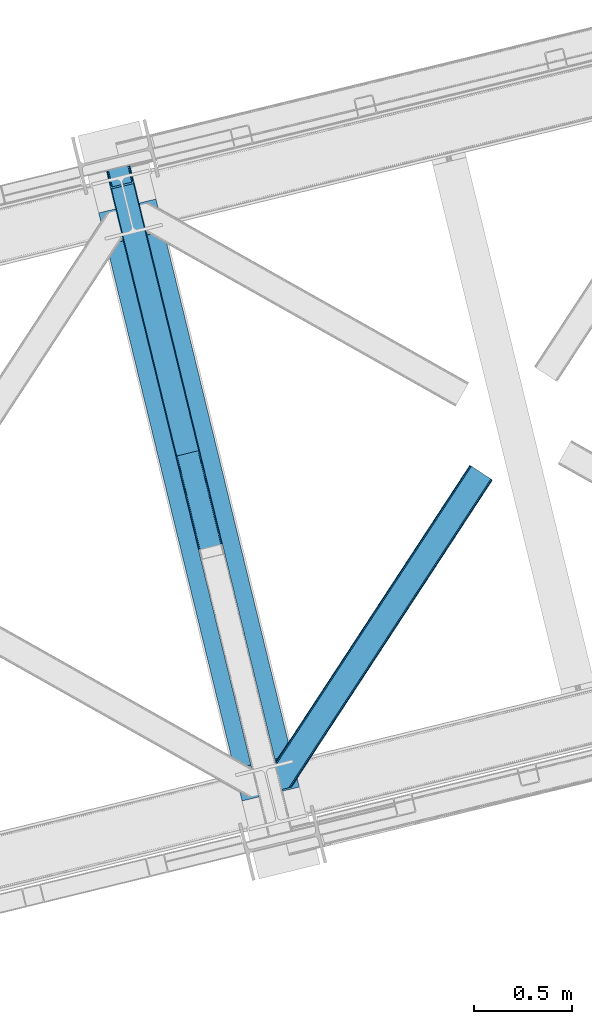
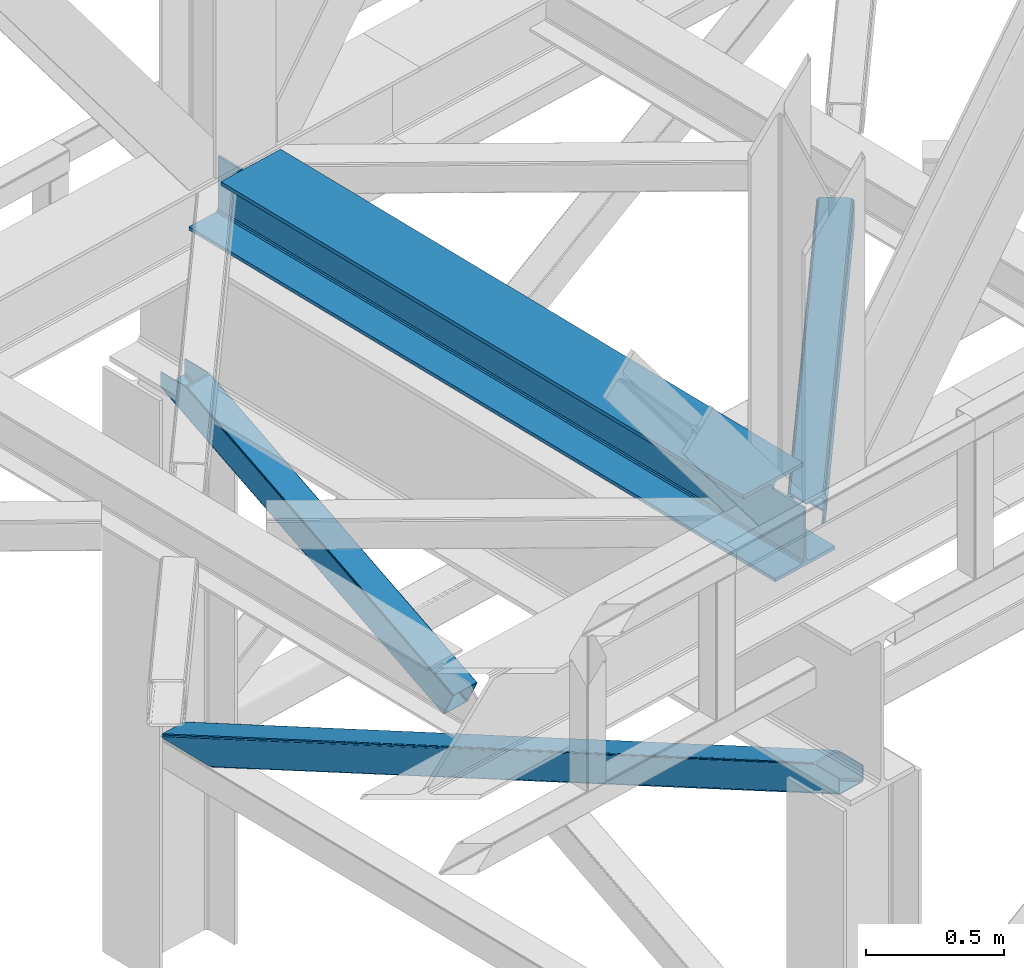
# One storey, part 45 of 92: 3 members, 1 beam.
"""IFC4 building model written with IfcOpenShell, lengths in millimetres."""

from ifc_helpers import new_model, entity, si_unit, converted_unit, derived_unit, direction, frame, origin, place, context, subcontext, project, spatial, triangles, polygons, material, type_object, element, save


model = new_model("IFC4")

# Units and contexts
model_context = context("Model", 3, precision=0.01, world=origin(), true_north=direction((6.12303176911189e-17, 1.0)))
plan_context = context("Plan", 3, precision=0.01, world=origin(), true_north=direction((6.12303176911189e-17, 1.0)))
body_context = subcontext(model_context, "Body", "Model", "MODEL_VIEW")
ifc_project = project(units=[si_unit("LENGTHUNIT", "METRE", prefix="MILLI"), si_unit("AREAUNIT", "SQUARE_METRE"), si_unit("VOLUMEUNIT", "CUBIC_METRE"), converted_unit("PLANEANGLEUNIT", "DEGREE", entity("IfcRatioMeasure", 0.0174532925199433), si_unit("PLANEANGLEUNIT", "RADIAN"), dimensions=[0, 0, 0, 0, 0, 0, 0]), si_unit("MASSUNIT", "GRAM", prefix="KILO"), derived_unit("MASSDENSITYUNIT", [(si_unit("MASSUNIT", "GRAM", prefix="KILO"), 1), (si_unit("LENGTHUNIT", "METRE"), -3)]), derived_unit("MOMENTOFINERTIAUNIT", [(si_unit("LENGTHUNIT", "METRE"), 4)]), si_unit("TIMEUNIT", "SECOND"), si_unit("FREQUENCYUNIT", "HERTZ"), si_unit("THERMODYNAMICTEMPERATUREUNIT", "DEGREE_CELSIUS"), derived_unit("THERMALTRANSMITTANCEUNIT", [(si_unit("MASSUNIT", "GRAM", prefix="KILO"), 1), (si_unit("THERMODYNAMICTEMPERATUREUNIT", "KELVIN"), -1), (si_unit("TIMEUNIT", "SECOND"), -3)]), derived_unit("VOLUMETRICFLOWRATEUNIT", [(si_unit("LENGTHUNIT", "METRE"), 3), (si_unit("TIMEUNIT", "SECOND"), -1)]), derived_unit("MASSFLOWRATEUNIT", [(si_unit("MASSUNIT", "GRAM", prefix="KILO"), 1), (si_unit("TIMEUNIT", "SECOND"), -1)]), derived_unit("ROTATIONALFREQUENCYUNIT", [(si_unit("TIMEUNIT", "SECOND"), -1)]), si_unit("ELECTRICCURRENTUNIT", "AMPERE"), si_unit("ELECTRICVOLTAGEUNIT", "VOLT"), si_unit("POWERUNIT", "WATT"), si_unit("FORCEUNIT", "NEWTON", prefix="KILO"), si_unit("ILLUMINANCEUNIT", "LUX"), si_unit("LUMINOUSFLUXUNIT", "LUMEN"), si_unit("LUMINOUSINTENSITYUNIT", "CANDELA"), derived_unit("USERDEFINED", [(si_unit("MASSUNIT", "GRAM", prefix="KILO"), -1), (si_unit("LENGTHUNIT", "METRE"), -2), (si_unit("TIMEUNIT", "SECOND"), 3), (si_unit("LUMINOUSFLUXUNIT", "LUMEN"), 1)]), derived_unit("LINEARVELOCITYUNIT", [(si_unit("LENGTHUNIT", "METRE"), 1), (si_unit("TIMEUNIT", "SECOND"), -1)]), si_unit("PRESSUREUNIT", "PASCAL"), derived_unit("USERDEFINED", [(si_unit("LENGTHUNIT", "METRE"), -2), (si_unit("MASSUNIT", "GRAM", prefix="KILO"), 1), (si_unit("TIMEUNIT", "SECOND"), -2)]), derived_unit("LINEARFORCEUNIT", [(si_unit("MASSUNIT", "GRAM", prefix="KILO"), 1), (si_unit("LENGTHUNIT", "METRE"), 1), (si_unit("TIMEUNIT", "SECOND"), -2), (si_unit("LENGTHUNIT", "METRE"), -1)]), derived_unit("PLANARFORCEUNIT", [(si_unit("MASSUNIT", "GRAM", prefix="KILO"), 1), (si_unit("LENGTHUNIT", "METRE"), 1), (si_unit("TIMEUNIT", "SECOND"), -2), (si_unit("LENGTHUNIT", "METRE"), -2)])], contexts=[model_context, plan_context])

# Site, building, storey
site_placement = place(None, origin())
site = spatial("IfcSite", under=ifc_project, at=site_placement, CompositionType="ELEMENT")
building_placement = place(site_placement, origin())
building = spatial("IfcBuilding", under=site, at=building_placement, CompositionType="ELEMENT")
storey_placement = place(building_placement, frame((0.0, 0.0, 15900.0)))
storey = spatial("IfcBuildingStorey", under=building, at=storey_placement, Name="05", CompositionType="ELEMENT", Elevation=15900.0)

# Beam
ifc_material = material(Name="Metal painted (White)")
beam_type = type_object("IfcBeamType", PredefinedType="BEAM")
beam_placement = place(storey_placement, frame((-43083.07, 7284.75, 3385.0)))
element("IfcBeam", 1, at=beam_placement, inside=storey, type_object=beam_type, material=ifc_material, ObjectType="Steel Beam", PredefinedType="BEAM", context=body_context, shape_type="Tessellation", body=[
    polygons([(1022.42935345712, 71.047827897101, 15.4999999999986), (1022.42935345712, 71.047827897101, 0.0), (291.465617442438, 3069.74325535076, 0.0), (291.465617442438, 3069.74325535076, 15.4999999999986), (899.042242073144, 40.970914087328, 15.4999999999986), (168.078506058474, 3039.66634154099, 15.4999999999986), (892.34989829919, 39.3395844888232, 16.8701684147963), (161.386162284511, 3038.03501194248, 16.8701684147963), (886.676403198575, 37.9566100336508, 20.7720779386413), (155.712667183895, 3036.65203748731, 20.7720779386413), (882.88549497, 37.0325360459173, 26.6116982174294), (151.92175895532, 3035.72796349958, 26.6116982174294), (881.554305026594, 36.7080444135029, 33.500000000001), (150.590569011924, 3035.40347186716, 33.500000000001), (140.875048430514, 3033.03521093726, 33.500000000001), (140.875048430505, 3033.03521093726, 259.000000000002), (150.590569011924, 3035.40347186716, 259.000000000002), (0.0, 2998.69542745366, 0.0), (0.0, 2998.69542745366, 15.4999999999986), (123.387111383964, 3028.77234126343, 15.4999999999986), (130.079455157918, 3030.40367086194, 16.8701684147963), (135.752950258533, 3031.78664531711, 20.7720779386413), (139.543858487117, 3032.71071930484, 26.6116982174294), (881.554305026594, 36.7080444135029, 259.000000000002), (871.838784445184, 34.3397834835992, 259.000000000002), (871.838784445184, 34.3397834835992, 33.500000000001), (870.507594501788, 34.0152918511848, 26.6116982174294), (866.716686273213, 33.0912178634502, 20.7720779386413), (861.043191172597, 31.7082434082767, 16.8701684147963), (854.350847398634, 30.0769138097741, 15.4999999999986), (730.963736014671, -1.08286712929839e-12, 15.4999999999986), (730.963736014671, -1.08286712929839e-12, 0.0), (841.854534586231, 199.571930111232, 259.069791776412), (190.199733064555, 2872.911390143, 259.000000000002), (190.423126166404, 2871.99494573803, 259.61730333112), (190.43551501003, 2871.94412150426, 266.500003008253), (841.709355772731, 200.167408132524, 266.500002998871), (841.709705893484, 200.16597182779, 260.000004007589), (832.229597305427, 196.831858094285, 259.006343172366), (832.006227290695, 197.748309612731, 259.61730333112), (831.99383844707, 197.799133846503, 266.500003008253), (180.719997684377, 2869.57584721824, 266.500002998871), (180.719647563625, 2869.57728352297, 260.000004007589), (180.57484190528, 2870.17133233676, 259.07612046749), (180.484212483136, 2870.5431292131, 259.000000000002), (843.040843642659, 200.490677577209, 273.388305639783), (846.831120231355, 201.417342749122, 279.227924098781), (852.504191178885, 202.8020572128, 283.129832400619), (859.196382860018, 204.434010743611, 284.500000377228), (982.583411547862, 234.511263798724, 284.500000138971), (982.58174174121, 234.518113867456, 299.999995328161), (691.116319643931, 163.469484603412, 299.999995890962), (691.117989450592, 163.462634534681, 284.500000701776), (814.505018138436, 193.539887589793, 284.500000463519), (821.197505034574, 195.170630056371, 283.129832461069), (826.871416683343, 196.551895700895, 279.227924137322), (830.662951470326, 197.473399350192, 273.388305663684), (179.388509814458, 2869.25257777355, 273.388305639783), (175.598233225762, 2868.32591260164, 279.227924098781), (169.925162278224, 2866.94119813796, 283.129832400619), (163.23297059709, 2865.30924460715, 284.500000377228), (39.8459419092461, 2835.23199155204, 284.500000138971), (39.8476117159065, 2835.2251414833, 299.999995328161), (331.313033813168, 2906.27377074735, 299.999995890962), (331.311364006516, 2906.28062081608, 284.500000701776), (207.924335318672, 2876.20336776097, 284.500000463519), (201.231848422534, 2874.57262529439, 283.129832461069), (195.557936773773, 2873.19135964986, 279.227924137322), (191.766401986782, 2872.26985600057, 273.388305663684)], [[[1, 2, 3, 4]], [[5, 1, 4, 6]], [[7, 5, 6, 8]], [[9, 7, 8, 10]], [[11, 9, 10, 12]], [[13, 11, 12, 14]], [[15, 16, 17, 14, 12, 10, 8, 6, 4, 3, 18, 19, 20, 21, 22, 23]], [[13, 24, 25, 26, 27, 28, 29, 30, 31, 32, 2, 1, 5, 7, 9, 11]], [[2, 32, 18, 3]], [[32, 31, 19, 18]], [[31, 30, 20, 19]], [[27, 26, 15, 23]], [[28, 27, 23, 22]], [[29, 28, 22, 21]], [[30, 29, 21, 20]], [[33, 24, 13, 14, 17, 34, 35, 36, 37, 38]], [[25, 39, 40, 41, 42, 43, 44, 16, 15, 26]], [[39, 25, 24, 33]], [[45, 34, 17, 16]], [[41, 40, 38, 37, 46, 47, 48, 49, 50, 51, 52, 53, 54, 55, 56, 57]], [[42, 58, 59, 60, 61, 62, 63, 64, 65, 66, 67, 68, 69, 36, 35, 43]], [[46, 37, 36, 69]], [[47, 46, 69, 68]], [[48, 47, 68, 67]], [[49, 48, 67, 66]], [[50, 49, 66, 65]], [[51, 50, 65, 64]], [[52, 51, 64, 63]], [[53, 52, 63, 62]], [[54, 53, 62, 61]], [[55, 54, 61, 60]], [[56, 55, 60, 59]], [[57, 56, 59, 58]], [[41, 57, 58, 42]]], closed=False),
])

# Members
member_type_1 = type_object("IfcMemberType", PredefinedType="BRACE")
member_1_placement = place(storey_placement, frame((-43055.13, 9044.28, 1820.91)))
element("IfcMember", 2, at=member_1_placement, inside=storey, type_object=member_type_1, ObjectType="Steel Vertical Brace", PredefinedType="BRACE", context=body_context, shape_type="Tessellation", body=[
    polygons([(29.8135191782804, 1388.61826467865, 771.091297096984), (32.1113287327941, 1381.7631169139, 771.091297096991), (368.111452939613, 3.36089743274961, 105.060837153753), (367.211709770158, 4.48063717441277, 102.289544138114), (35.2425975620211, 1376.24004026086, 771.091297096982), (370.05749831742, 2.70006492288988, 107.410225929579), (38.7306183717081, 1372.88987307313, 771.091297096984), (372.753578135707, 2.59874540397811, 108.980037321763), (42.0443716126081, 1372.2226479357, 771.091297096984), (375.789238682186, 3.07236385431782, 109.531281776207), (140.171129484899, 1396.14208332772, 771.091297096984), (473.915996554477, 26.9917992463432, 109.531281776209), (142.8061262653, 1398.25937921938, 771.091297096991), (476.829086029282, 27.9682515502273, 108.980037321769), (144.361212211704, 1402.83885703393, 771.091297096989), (479.176112967095, 29.2988816959539, 107.410225929583), (144.599639585679, 1409.18333278718, 771.091297096997), (480.599763792498, 30.7811133060287, 105.060837153757), (143.485109980834, 1416.32691755852, 771.091297096984), (480.883300572703, 32.1892900542821, 102.289544138114), (149.600536197998, 1408.12910918704, 771.09129709698), (121.444007267685, 1523.63806044727, 771.091297096982), (117.557799035119, 1522.69075607531, 771.09129709698), (3.88620823256572, 1494.98210319545, 771.091297096982), (0.0, 1494.03479882349, 771.091297096982), (28.1565289303128, 1378.52584756325, 771.09129709698), (30.4543384848352, 1371.6706997985, 771.091297096982), (33.5856073140622, 1366.14762314545, 771.091297096982), (37.0736281237578, 1362.79745595772, 771.091297096984), (40.3873813646492, 1362.1302308203, 771.09129709698), (146.286555702072, 1387.94427495624, 771.09129709698), (148.921552482473, 1390.06157084789, 771.091297096984), (150.476638428877, 1394.64104866244, 771.09129709698), (150.715065802835, 1400.9855244157, 771.09129709698), (359.725704690137, 52.0811507006387, 4.33146851719357e-12), (465.62487902756, 77.8951948365855, 2.16573425859679e-12), (468.660539574047, 78.3688132869252, 0.551244454446396), (471.356619392334, 78.2674937680167, 2.12105584662818), (473.302664770132, 77.6066612581483, 4.4704446224671), (474.202407939596, 76.4869215164884, 7.24173763810153), (485.172065028726, 31.4851533942341, 105.910412957166), (484.888528248495, 30.076976645984, 108.681705972796), (483.464877423117, 28.5947450359069, 111.031094748631), (481.117850485313, 27.2641148901782, 112.600906140819), (478.204761010508, 26.2876625862941, 113.152150595261), (372.305586673086, 0.473618450346206, 113.152150595257), (369.26992612659, 4.33146851719357e-12, 112.600906140819), (366.573846308302, 0.1013195189161, 111.031094748635), (364.627800930504, 0.762152028780159, 108.681705972796), (363.728057761041, 1.88189177044223, 105.910412957166), (352.758400671911, 46.8836598926955, 7.24173763810153), (353.041937452133, 48.2918366409467, 4.4704446224671), (354.465588277511, 49.7740682510248, 2.12105584662385), (356.812615215332, 51.1046983967513, 0.551244454448562), (470.718755930487, 73.8881761125179, 10.8626064571491), (469.819012761015, 75.0079158541778, 8.09131344151462), (467.872967383234, 75.6687483640494, 5.74192466567137), (465.17688756493, 75.7700678829514, 4.17211327349608), (462.141227018451, 75.296449432615, 3.62086881905185), (364.01446914616, 51.3770140405907, 3.62086881905185), (361.101379671346, 50.4005617367033, 4.17211327349392), (358.754352733533, 49.0699315909757, 5.74192466567787), (357.330701908147, 47.5876999809008, 8.09131344151462), (357.047165127933, 46.1795232326485, 10.8626064571491), (3.88620823255706, 1494.98210319545, 710.909831470177), (117.557799035128, 1522.69075607532, 710.909831470177), (11.6586246976972, 1496.87671193937, 702.072173549059), (8.91066050333388, 1496.20686659411, 703.366418586696), (6.16269630898794, 1495.53702124884, 704.660663624354), (5.02445227077683, 1495.25956222214, 707.785247547264), (116.419554996891, 1522.41329704861, 707.785247547264), (115.28131095868, 1522.13583802191, 704.660663624352), (112.533346764334, 1521.46599267665, 703.3664185867), (109.785382569988, 1520.79614733139, 702.072173549057), (120.305763229465, 1523.36060142058, 703.366418586704), (119.167519191254, 1523.08314239388, 700.241834663787), (116.4195549969, 1522.41329704862, 698.94758962614), (113.671590802554, 1521.74345170335, 697.653344588497), (7.77241646513144, 1495.92940756741, 697.653344588497), (5.02445227077683, 1495.25956222214, 698.947589626138), (2.27648807642222, 1494.58971687688, 700.241834663785), (1.13824403821977, 1494.31225785018, 703.366418586702), (0.0, 1494.03479882349, 706.491002509615), (121.444007267685, 1523.63806044727, 706.491002509615)], [[[1, 2, 3, 4]], [[2, 5, 6, 3]], [[5, 7, 8, 6]], [[7, 9, 10, 8]], [[9, 11, 12, 10]], [[11, 13, 14, 12]], [[13, 15, 16, 14]], [[15, 17, 18, 16]], [[17, 19, 20, 18]], [[21, 22, 23, 19, 17, 15, 13, 11, 9, 7, 5, 2, 1, 24, 25, 26, 27, 28, 29, 30, 31, 32, 33, 34]], [[35, 36, 37, 38, 39, 40, 41, 42, 43, 44, 45, 46, 47, 48, 49, 50, 51, 52, 53, 54], [55, 56, 57, 58, 59, 60, 61, 62, 63, 64, 4, 3, 6, 8, 10, 12, 14, 16, 18, 20]], [[24, 1, 4, 64, 65]], [[19, 23, 66, 55, 20]], [[61, 67, 68]], [[62, 68, 69]], [[63, 69, 70]], [[64, 70, 65]], [[70, 64, 63]], [[69, 63, 62]], [[68, 62, 61]], [[67, 61, 60]], [[55, 71, 56]], [[56, 72, 57]], [[57, 73, 58]], [[58, 74, 59]], [[74, 58, 73]], [[73, 57, 72]], [[72, 56, 71]], [[71, 55, 66]], [[74, 67, 60, 59]], [[75, 76, 77, 78, 79, 80, 81, 82, 83, 25, 24, 65, 70, 69, 68, 67, 74, 73, 72, 71, 66, 23, 22, 84]], [[30, 29, 47, 46]], [[29, 28, 48, 47]], [[28, 27, 49, 48]], [[27, 26, 50, 49]], [[45, 31, 30, 46]], [[21, 34, 42, 41]], [[34, 33, 43, 42]], [[33, 32, 44, 43]], [[32, 31, 45, 44]], [[50, 26, 25, 83, 51]], [[84, 22, 21, 41, 40]], [[51, 82, 52]], [[52, 81, 53]], [[53, 80, 54]], [[54, 79, 35]], [[79, 54, 80]], [[80, 53, 81]], [[81, 52, 82]], [[82, 51, 83]], [[37, 78, 77]], [[38, 77, 76]], [[39, 76, 75]], [[40, 75, 84]], [[75, 40, 39]], [[76, 39, 38]], [[77, 38, 37]], [[78, 37, 36]], [[35, 79, 78, 36]]], closed=True),
])
member_type_2 = type_object("IfcMemberType", PredefinedType="BRACE")
member_2_placement = place(storey_placement, frame((-43055.13, 7071.33, 970.5)))
element("IfcMember", 3, at=member_2_placement, inside=storey, type_object=member_type_2, ObjectType="Steel Vertical Brace", PredefinedType="BRACE", context=body_context, shape_type="Tessellation", body=[
    triangles([(177.817053222658, 3231.5446105957, 0.0), (958.783337402347, 27.7087738037108, 1548.06132202148), (852.887475585943, 1.89465179443323, 1548.06132202148), (71.9165405273452, 3205.72990722656, 0.0), (961.532006835943, 28.3785003662106, 1549.35542907715), (964.280676269533, 29.0482269287113, 1550.65069885254), (180.449450683598, 3233.66192321777, 0.0), (965.420141601564, 29.3255355834963, 1553.77492675781), (182.007495117192, 3238.24071350098, 0.0), (966.559606933595, 29.6034255981449, 1556.89915466309), (182.244689941406, 3244.58567504883, 0.0), (181.128479003906, 3251.72942504883, 0.0), (845.115856933597, 0.0, 1556.89915466309), (59.6847290039077, 3222.12541809082, 0.0), (61.9822631835996, 3215.27118530273, 0.0), (846.250671386719, 0.277308654784974, 1553.77492675781), (65.1169555664092, 3209.74710388184, 0.0), (847.39013671875, 0.554617309569949, 1550.65069885254), (68.6051147460967, 3206.39730834961, 0.0), (850.138806152347, 1.22492523193341, 1549.35542907715), (121.443750000006, 3496.58657226562, 2.0998718261726), (938.403186035161, 145.112072753906, 1621.4998626709), (121.443750000006, 3496.58657226562, 0.0), (966.559606933595, 29.6034255981449, 1621.4998626709), (0.0, 3466.98372802734, 2.0998718261726), (816.954785156253, 115.508647155762, 1621.4998626709), (0.0, 3466.98372802734, 0.0), (845.115856933597, 0.0, 1621.4998626709), (116.420800781256, 3495.36222839356, 9.64359741210865), (113.672131347659, 3494.69250183105, 10.9377044677749), (926.171374511723, 161.507583618164, 1621.4998626709), (119.164819335943, 3496.03195495605, 8.34949035644604), (929.482800292972, 160.840763854981, 1621.4998626709), (120.304284667975, 3496.30868225098, 5.22409973144386), (932.970959472659, 157.490386962891, 1621.4998626709), (936.105651855469, 151.967468261719, 1621.4998626709), (7.77161865234666, 3468.87779846191, 10.9377044677749), (820.270861816411, 135.69404296875, 1621.4998626709), (815.843225097662, 122.652397155762, 1621.4998626709), (1.13946533203125, 3467.26045532227, 5.22409973144386), (816.080419921876, 128.99677734375, 1621.4998626709), (2.27427978516062, 3467.53834533692, 8.34949035644604), (817.633813476568, 133.576148986816, 1621.4998626709), (5.02294921875, 3468.20807189941, 9.64359741210865), (4.15788574219187, 3467.99645690918, 0.0), (4.76250000000437, 3468.14528503418, 0.782510375975107), (6.7437744140625, 3468.6278137207, 3.34281921386719), (117.285864257814, 3495.57268066406, 0.0), (116.797521972658, 3495.45408325195, 0.95459289550854), (115.281335449225, 3495.08433837891, 3.92999267578125), (8.68319091797457, 3469.09987792969, 5.84615478515479), (109.783996582031, 3493.74488525391, 6.51936950683739), (11.6597534179746, 3469.82541503906, 6.51936950683739), (112.532666015628, 3494.41461181641, 5.22409973144386), (924.511010742193, 151.415176391602, 1621.4998626709), (826.386767578129, 127.496287536621, 1621.4998626709), (118.727636718751, 3490.84157409668, 0.0), (936.742822265631, 135.019665527344, 1621.4998626709), (934.445288085939, 141.875061035156, 1621.4998626709), (931.315246582031, 147.397979736328, 1621.4998626709), (927.827087402344, 150.748356628418, 1621.4998626709), (962.671472167975, 28.6558090209965, 1621.4998626709), (822.196325683595, 120.799603271485, 1621.4998626709), (823.749719238287, 125.378974914551, 1621.4998626709), (823.070690917972, 107.310891723633, 1621.4998626709), (821.959130859381, 114.454641723632, 1621.4998626709), (848.999340820315, 0.947035217284792, 1621.4998626709), (5.05550537109957, 3463.13280029297, 0.0), (175.012573242188, 3259.92659912109, 0.0), (962.671472167975, 28.6558090209965, 1561.31865234375), (61.3450927734375, 3232.21782531738, 0.0), (848.999340820315, 0.947035217284792, 1561.31865234375), (66.7726684570371, 3219.84067382813, 0.0), (63.6426269531294, 3225.3635925293, 0.0), (70.2608276367246, 3216.48971557617, 0.0), (73.576904296875, 3215.82231445312, 0.0), (175.891589355473, 3246.43905029297, 0.0), (176.128784179688, 3252.78401184082, 0.0), (174.338195800781, 3241.85909729004, 0.0), (171.701147460939, 3239.74178466797, 0.0), (954.899853515628, 26.7611572265623, 1552.48081970215), (957.648522949225, 27.4314651489258, 1553.77492675781), (960.392541503912, 28.1011917114256, 1555.06903381348), (856.770959472662, 2.84226837158167, 1552.48081970215), (854.022290039065, 2.17196044921911, 1553.77492675781), (851.278271484378, 1.50223388671839, 1555.06903381348), (961.532006835943, 28.3785003662106, 1558.19326171875), (850.138806152347, 1.22492523193341, 1558.19326171875)], [[1, 2, 3], [3, 4, 1], [5, 2, 1], [6, 5, 7], [8, 6, 9], [10, 8, 11], [11, 12, 10], [9, 11, 8], [7, 9, 6], [1, 7, 5], [13, 14, 15], [16, 15, 17], [18, 17, 19], [20, 19, 4], [4, 3, 20], [19, 20, 18], [17, 18, 16], [15, 16, 13], [12, 21, 22], [12, 23, 21], [22, 10, 12], [24, 10, 22], [25, 14, 26], [14, 25, 27], [13, 26, 14], [28, 26, 13], [29, 30, 31], [32, 29, 33], [34, 32, 35], [21, 34, 36], [36, 22, 21], [35, 36, 34], [33, 35, 32], [31, 33, 29], [31, 30, 37], [37, 38, 31], [25, 26, 39], [40, 39, 41], [42, 41, 43], [44, 43, 38], [38, 37, 44], [43, 44, 42], [41, 42, 40], [39, 40, 25], [45, 25, 46], [45, 27, 25], [46, 40, 47], [40, 42, 47], [25, 40, 46], [48, 21, 23], [21, 48, 49], [49, 34, 21], [34, 49, 50], [47, 44, 51], [37, 30, 52], [53, 51, 37], [52, 53, 37], [51, 44, 37], [42, 44, 47], [30, 54, 52], [29, 50, 54], [50, 32, 34], [50, 29, 32], [30, 29, 54], [52, 55, 56], [56, 53, 52], [57, 58, 59], [49, 48, 57], [49, 59, 60], [50, 60, 61], [54, 61, 55], [55, 52, 54], [61, 54, 50], [60, 50, 49], [59, 49, 57], [61, 60, 36], [35, 61, 36], [61, 35, 33], [55, 31, 38], [33, 55, 61], [31, 55, 33], [60, 22, 36], [24, 58, 62], [24, 22, 58], [60, 59, 22], [59, 58, 22], [39, 63, 64], [38, 56, 55], [56, 43, 64], [43, 56, 38], [64, 41, 39], [41, 64, 43], [26, 63, 39], [65, 66, 26], [66, 63, 26], [65, 28, 67], [26, 28, 65], [47, 51, 64], [46, 47, 63], [68, 46, 66], [66, 65, 68], [68, 45, 46], [63, 66, 46], [64, 63, 47], [53, 56, 51], [64, 51, 56], [58, 69, 70], [58, 57, 69], [70, 62, 58], [71, 65, 72], [65, 71, 68], [67, 72, 65], [73, 15, 14], [27, 68, 71], [68, 27, 45], [14, 71, 74], [71, 14, 27], [74, 73, 14], [75, 15, 73], [17, 75, 19], [17, 15, 75], [19, 76, 4], [4, 76, 1], [75, 76, 19], [12, 11, 77], [78, 69, 12], [77, 78, 12], [23, 57, 48], [69, 23, 12], [57, 23, 69], [11, 79, 77], [80, 7, 1], [80, 1, 76], [80, 79, 7], [79, 9, 7], [79, 11, 9], [81, 3, 2], [2, 5, 82], [6, 83, 5], [83, 82, 5], [2, 82, 81], [83, 6, 8], [84, 3, 81], [20, 85, 86], [20, 3, 85], [86, 18, 20], [18, 86, 16], [84, 85, 3], [87, 10, 70], [8, 87, 83], [10, 87, 8], [24, 70, 10], [24, 62, 70], [16, 88, 13], [13, 88, 72], [86, 88, 16], [72, 28, 13], [28, 72, 67], [81, 80, 84], [76, 84, 80], [70, 69, 78], [87, 78, 77], [83, 77, 79], [82, 79, 80], [80, 81, 82], [79, 82, 83], [77, 83, 87], [78, 87, 70], [85, 84, 76], [86, 85, 75], [88, 86, 73], [72, 88, 74], [74, 71, 72], [73, 74, 88], [75, 73, 86], [76, 75, 85]]),
])
member_type_3 = type_object("IfcMemberType", PredefinedType="BRACE")
member_3_placement = place(storey_placement, frame((-42217.82, 7332.57, 3511.0)))
element("IfcMember", 4, at=member_3_placement, inside=storey, type_object=member_type_3, ObjectType="Steel Horizontal Brace", PredefinedType="BRACE", context=body_context, shape_type="Tessellation", body=[
    triangles([(109.770043945311, 259.950411987305, 7.52047119140843), (115.034838867192, 238.366264343262, 7.77510681152489), (114.220935058598, 239.947563171387, 8.3320495605476), (108.811962890628, 259.663220214844, 8.52041015625218), (113.639575195317, 239.860359191895, 8.52041015625218), (112.211755371092, 237.678515625, 8.52041015625218), (91.0363037109419, 232.517202758789, 8.52041015625218), (109.537499999999, 237.026229858398, 9.50058288574292), (90.2642578125015, 232.328842163086, 9.50058288574292), (5.02294921875, 77.405158996582, 9.50058288574292), (0.62786865234375, 95.4313842773436, 9.50058288574292), (1046.62448730469, 1651.75382995605, 6.99957275390625), (1041.02482910157, 1655.42279205322, 8.3320495605476), (116.704504394533, 231.514938354492, 6.99957275390625), (1036.27163085937, 1658.53248596191, 12.1260040283232), (3.93464355469041, 81.8758163452148, 12.1260040283232), (1033.09973144531, 1660.61084747314, 17.8035644531265), (2.70216064453416, 86.9220199584961, 17.8035644531265), (1031.98352050781, 1661.3398727417, 24.4996673583992), (2.26962890625146, 88.6945861816403, 24.4996673583992), (1122.759375, 1601.905128479, 6.99957275390625), (146.20968017578, 110.459536743164, 6.99957275390625), (1031.98352050781, 1661.3398727417, 115.501089477541), (2.26962890625146, 88.6945861816403, 115.501089477541), (1033.09973144531, 1660.61084747314, 122.196029663086), (2.70216064453416, 86.9220199584961, 122.196029663086), (1036.27163085937, 1658.53248596191, 127.87475280762), (3.93464355469041, 81.8758163452148, 127.87475280762), (1041.02482910157, 1655.42279205322, 131.667544555665), (5.77174072265916, 74.3233703613278, 131.667544555665), (1046.62448730469, 1651.75382995605, 133.000021362306), (7.94370117187646, 65.4146118164063, 133.000021362306), (1027.24427490235, 1664.44491577148, 10.8028289794929), (0.520898437498545, 95.8720550537109, 10.8691040039084), (0.0, 98.0062271118168, 17.5000946044929), (1035.16472167969, 1659.25686035156, 1.33247680664135), (112.262915039064, 249.735919189453, 1.33247680664135), (110.546740722661, 256.77269897461, 5.59500732422021), (109.077062988283, 259.839953613281, 8.31925964355469), (1030.41617431641, 1662.36713562012, 5.12526855468968), (1040.76903076172, 1655.58847961426, 0.0), (114.434875488281, 240.827160644531, 0.0), (1026.12806396485, 1665.1745223999, 17.5000946044929), (1128.61483154297, 1598.07106018066, 0.0), (148.479309082031, 101.147895812988, 0.0), (150.651269531249, 92.2391372680668, 1.33247680664135), (148.511865234374, 101.029879760742, 8.50064392089917), (152.493017578126, 84.6866912841797, 5.12526855468968), (153.348779296874, 81.1828353881838, 8.50064392089917), (1026.12806396485, 1665.1745223999, 122.500662231447), (0.0, 98.0062271118168, 122.500662231447), (1040.76903076172, 1655.58847961426, 139.999594116212), (1035.16472167969, 1659.25686035156, 138.667117309571), (3.50211181640771, 83.6350112915043, 138.667117309571), (5.674072265625, 74.7262527465818, 139.999594116212), (1030.41617431641, 1662.36713562012, 134.874325561526), (1.66501464843896, 91.1874572753904, 134.874325561526), (1027.24427490235, 1664.44491577148, 129.197927856447), (0.432531738282705, 96.2342422485353, 129.197927856447), (23.8915649414048, 0.0, 139.999594116212), (23.8915649414048, 0.0, 133.000021362306), (1128.61483154297, 1598.07106018066, 139.999594116212), (93.3384887695356, 16.9286178588864, 139.999594116212), (1122.759375, 1601.905128479, 133.000021362306), (83.3809570312515, 14.5014404296871, 133.000021362306), (1143.25579833984, 1588.48443603516, 122.500662231447), (1142.13958740234, 1589.21404266357, 129.197927856447), (118.225341796875, 22.9956893920898, 122.500662231447), (116.332434082033, 22.5340896606449, 129.197927856447), (1138.96768798828, 1591.2924041748, 134.874325561526), (110.937414550783, 21.219053649902, 134.874325561526), (1134.2144897461, 1594.4020980835, 138.667117309571), (102.86348876953, 19.2505691528322, 138.667117309571), (1143.25579833984, 1588.48443603516, 17.5000946044929), (118.225341796875, 22.9956893920898, 17.5000946044929), (1142.13958740234, 1589.21404266357, 10.8028289794929), (1133.11223144532, 1595.12705383301, 12.1260040283232), (1136.28413085938, 1593.04869232178, 17.8035644531265), (1137.40034179688, 1592.31908569336, 24.4996673583992), (1138.96768798828, 1591.2924041748, 5.12526855468968), (1134.2144897461, 1594.4020980835, 1.33247680664135), (1128.35903320312, 1598.2367477417, 8.3320495605476), (1133.11223144532, 1595.12705383301, 127.87475280762), (1137.40034179688, 1592.31908569336, 115.501089477541), (1136.28413085938, 1593.04869232178, 122.196029663086), (1128.35903320312, 1598.2367477417, 131.667544555665), (92.9059570312529, 16.823391723633, 131.667544555665), (100.979882812499, 18.7918762207028, 127.87475280762), (106.374902343749, 20.1069122314457, 122.196029663086), (108.2724609375, 20.5690933227543, 115.501089477541), (108.2724609375, 20.5690933227543, 24.4996673583992), (100.979882812499, 18.7918762207028, 12.1260040283232), (115.472021484376, 22.3248001098636, 9.50058288574292), (106.374902343749, 20.1069122314457, 17.8035644531265), (96.2034301757813, 17.6268310546875, 9.50058288574292), (115.946411132813, 22.4393280029299, 10.8702667236357), (153.065075683597, 80.2398696899418, 9.00061340332104), (152.776721191411, 79.2974853515625, 9.50058288574292), (148.711853027344, 99.8683227539059, 8.8831787109375), (148.604882812499, 99.0241882324217, 9.08781738281323), (148.493261718751, 98.1678451538082, 9.29478149414354), (148.386291503906, 97.3231292724613, 9.50058288574292)], [[1, 2, 3], [4, 5, 6], [6, 7, 4], [7, 6, 8], [8, 9, 7], [9, 8, 10], [10, 11, 9], [12, 13, 3], [3, 2, 12], [2, 14, 12], [15, 16, 8], [8, 13, 15], [8, 5, 13], [16, 10, 8], [8, 6, 5], [15, 17, 18], [18, 16, 15], [17, 19, 20], [20, 18, 17], [21, 12, 14], [14, 22, 21], [19, 23, 20], [24, 20, 23], [23, 25, 24], [26, 24, 25], [25, 27, 26], [28, 26, 27], [27, 29, 28], [30, 28, 29], [29, 31, 30], [32, 30, 31], [33, 34, 35], [36, 37, 38], [33, 4, 9], [33, 1, 39], [9, 34, 33], [9, 11, 34], [4, 7, 9], [40, 38, 1], [1, 33, 40], [38, 40, 36], [36, 41, 37], [42, 37, 41], [35, 43, 33], [41, 44, 42], [45, 42, 44], [14, 42, 22], [37, 2, 38], [2, 37, 42], [38, 2, 1], [42, 14, 2], [22, 42, 45], [46, 47, 45], [47, 46, 48], [45, 47, 22], [48, 49, 47], [50, 43, 35], [35, 51, 50], [52, 53, 54], [54, 55, 52], [53, 56, 57], [57, 54, 53], [56, 58, 59], [59, 57, 56], [58, 50, 51], [51, 59, 58], [28, 57, 26], [30, 32, 55], [32, 60, 55], [32, 61, 60], [54, 30, 55], [28, 54, 57], [16, 11, 10], [28, 30, 54], [51, 35, 20], [24, 26, 51], [24, 51, 20], [57, 59, 26], [26, 59, 51], [35, 18, 20], [18, 11, 16], [11, 18, 34], [35, 34, 18], [62, 55, 63], [62, 52, 55], [55, 60, 63], [64, 32, 31], [32, 64, 65], [61, 32, 65], [66, 67, 68], [69, 68, 67], [67, 70, 69], [71, 69, 70], [70, 72, 71], [73, 71, 72], [72, 62, 73], [63, 73, 62], [74, 66, 68], [68, 75, 74], [76, 77, 78], [79, 66, 74], [76, 78, 74], [76, 80, 77], [78, 79, 74], [77, 80, 81], [21, 44, 41], [44, 82, 81], [82, 44, 21], [82, 77, 81], [67, 83, 70], [84, 66, 79], [66, 85, 67], [85, 66, 84], [67, 85, 83], [62, 64, 52], [72, 70, 83], [83, 86, 72], [86, 64, 62], [62, 72, 86], [15, 36, 40], [41, 12, 21], [41, 13, 12], [13, 41, 36], [15, 13, 36], [19, 43, 50], [33, 17, 15], [40, 33, 15], [17, 33, 43], [19, 17, 43], [53, 27, 56], [52, 64, 31], [31, 29, 52], [29, 27, 53], [53, 52, 29], [58, 56, 27], [50, 23, 19], [25, 50, 58], [50, 25, 23], [25, 58, 27], [64, 86, 87], [87, 65, 64], [86, 83, 88], [88, 87, 86], [83, 85, 89], [89, 88, 83], [85, 84, 90], [90, 89, 85], [84, 79, 90], [91, 90, 79], [89, 68, 69], [87, 73, 63], [60, 65, 63], [65, 60, 61], [65, 87, 63], [88, 73, 87], [88, 89, 71], [71, 73, 88], [69, 71, 89], [91, 75, 68], [92, 93, 94], [89, 90, 68], [92, 95, 93], [91, 94, 75], [90, 91, 68], [96, 75, 94], [94, 93, 96], [76, 74, 75], [49, 80, 97], [98, 97, 80], [49, 48, 80], [76, 96, 98], [98, 80, 76], [96, 93, 98], [44, 81, 45], [46, 45, 81], [81, 80, 46], [48, 46, 80], [75, 96, 76], [82, 21, 22], [77, 82, 47], [47, 99, 77], [77, 100, 101], [100, 77, 99], [101, 102, 77], [77, 102, 92], [95, 92, 102], [22, 47, 82], [79, 78, 91], [94, 91, 78], [78, 77, 94], [92, 94, 77], [102, 101, 98], [101, 100, 97], [100, 99, 49], [99, 47, 49], [102, 98, 93], [93, 95, 102]]),
])

save(model, "model.ifc")
